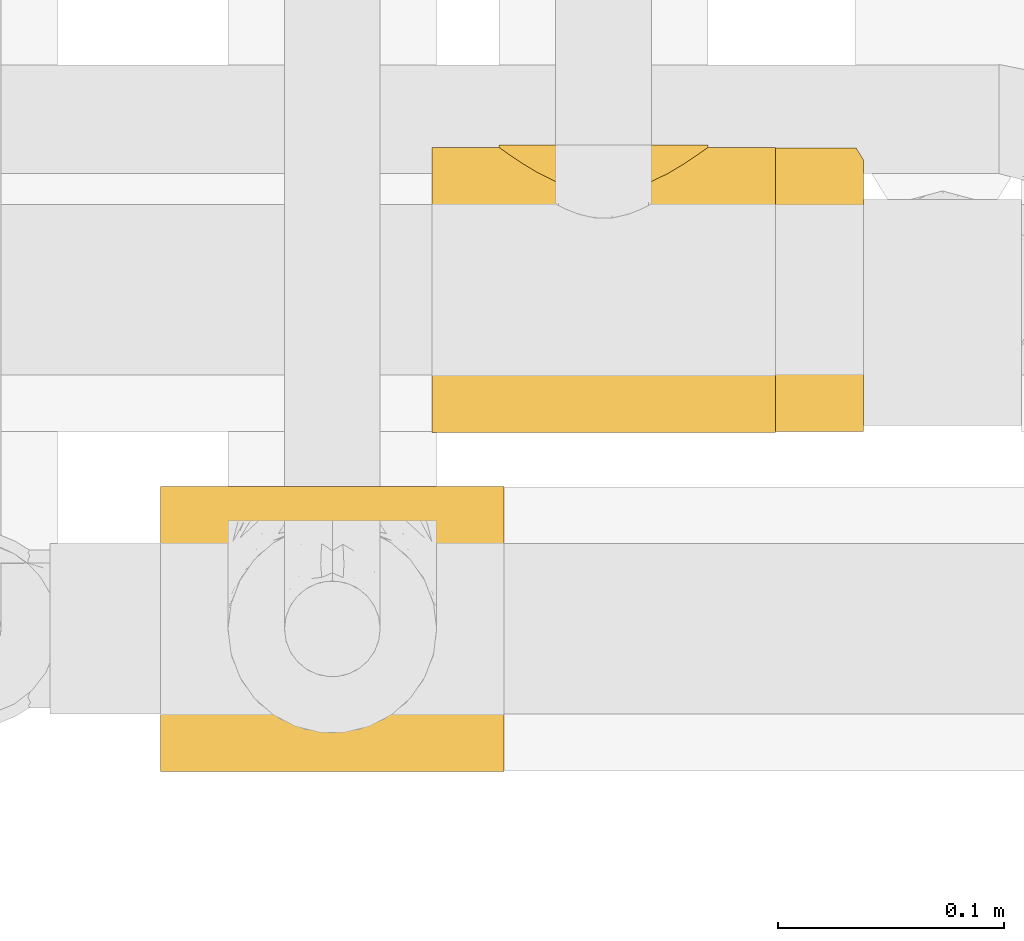
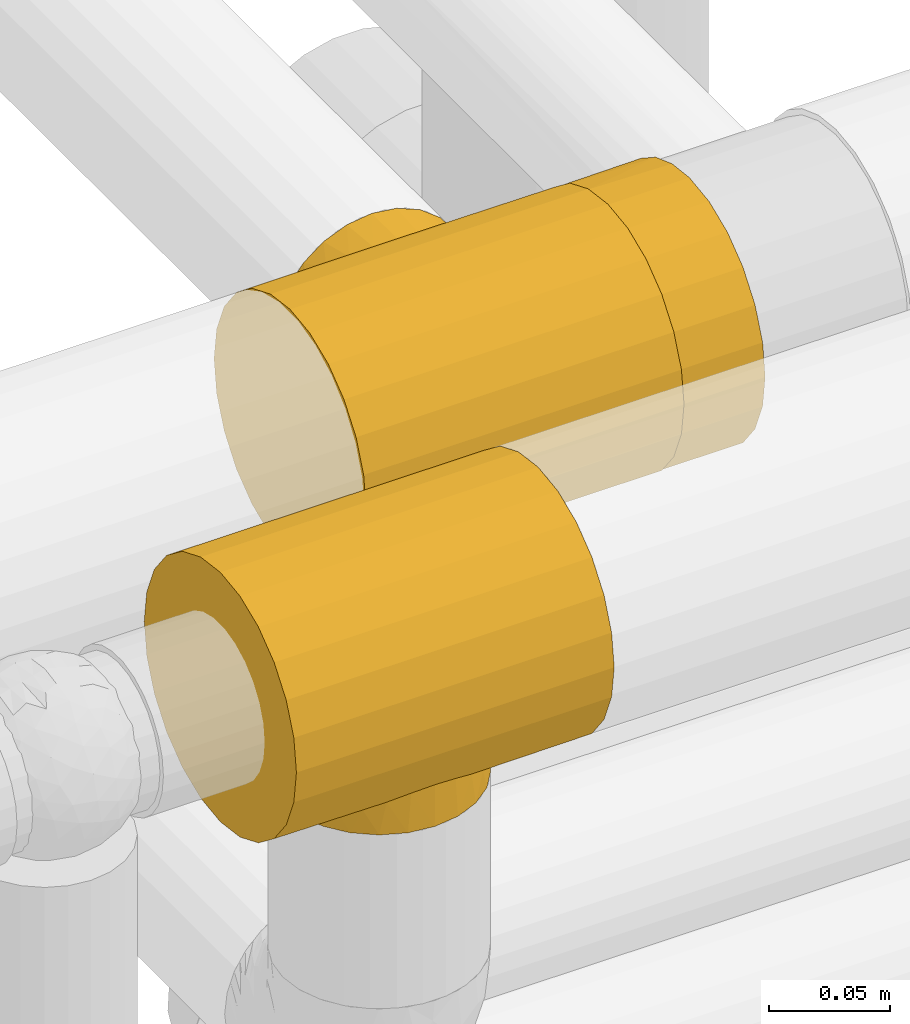
# One storey, part 419 of 827: 3 coverings.
"""IFC2X3 building model written with IfcOpenShell, lengths in millimetres."""

import ifcopenshell
import ifcopenshell.guid

model = None  # the IFC model being written
_history = None  # IfcOwnerHistory: only IFC2X3 demands one
_inside = {}  # id of a spatial element -> (the spatial element, [elements in it])
_under = {}  # id of a project, library or spatial element -> (it, [spatial elements below it])
_declared = {}  # id of a project -> (the project, [libraries it declares])
_typed = {}  # id of a type object -> (the type object, [elements of that type])
_made_of = {}  # id of a material, layer set ... -> (it, [elements and type objects made of it])


def new_model(schema):
    """Start an empty IFC model of exactly this schema.

    Asked for "IFC4X3", IfcOpenShell would pick the latest addendum, in which some entities
    have other attributes; the version numbers below select the first issue.
    IFC2X3 requires an IfcOwnerHistory on every rooted entity: one is made here for all.
    """
    global model, _history
    if schema == "IFC4X3":
        model = ifcopenshell.file(schema_version=(4, 3, 0, 0))
    else:
        model = ifcopenshell.file(schema=schema)
    _inside.clear()
    _under.clear()
    _declared.clear()
    _typed.clear()
    _made_of.clear()
    _history = None
    if model.schema == "IFC2X3":
        org = make("IfcOrganization", Name="unknown")
        user = make(
            "IfcPersonAndOrganization",
            ThePerson=make("IfcPerson", FamilyName="unknown"),
            TheOrganization=org,
        )
        app = make(
            "IfcApplication",
            ApplicationDeveloper=org,
            Version="unknown",
            ApplicationFullName="unknown",
            ApplicationIdentifier="unknown",
        )
        _history = make(
            "IfcOwnerHistory",
            OwningUser=user,
            OwningApplication=app,
            ChangeAction="ADDED",
            CreationDate=0,
        )
    return model


def make(cls, **values):
    """One entity of the class cls with the attributes given. An attribute that is None is left unset."""
    return model.create_entity(
        cls, **{name: value for name, value in values.items() if value is not None}
    )


def entity(cls, *values):
    """Any entity or typed value of the class cls, its attributes in the order of the schema. None: left unset."""
    e = model.create_entity(cls)
    for i, value in enumerate(values):
        if value is not None:
            e[i] = value
    return e


def rooted(cls, **values):
    """An entity with a GlobalId (a new one), such as an element, a storey or a relation."""
    return make(cls, GlobalId=ifcopenshell.guid.new(), OwnerHistory=_history, **values)


def si_unit(unit_type, name, prefix=None):
    """IfcSIUnit, for example si_unit("LENGTHUNIT", "METRE", prefix="MILLI")."""
    return make("IfcSIUnit", UnitType=unit_type, Prefix=prefix, Name=name)


def converted_unit(unit_type, name, factor, base, dimensions=None, offset=None):
    """IfcConversionBasedUnit, such as the inch: factor (a typed value) times the base unit."""
    return make(
        "IfcConversionBasedUnit"
        if offset is None
        else "IfcConversionBasedUnitWithOffset",
        ConversionOffset=offset,
        Dimensions=None
        if dimensions is None
        else entity("IfcDimensionalExponents", *dimensions),
        UnitType=unit_type,
        Name=name,
        ConversionFactor=make(
            "IfcMeasureWithUnit", ValueComponent=factor, UnitComponent=base
        ),
    )


def derived_unit(unit_type, elements):
    """IfcDerivedUnit: a product of units, each with its exponent."""
    return make(
        "IfcDerivedUnit",
        Elements=[
            make("IfcDerivedUnitElement", Unit=unit, Exponent=power)
            for unit, power in elements
        ],
        UnitType=unit_type,
    )


def assignment(units):
    """IfcUnitAssignment: the units of a project."""
    return None if units is None else make("IfcUnitAssignment", Units=units)


def point(xyz):
    """IfcCartesianPoint."""
    return None if xyz is None else make("IfcCartesianPoint", Coordinates=xyz)


def direction(xyz):
    """IfcDirection."""
    return None if xyz is None else make("IfcDirection", DirectionRatios=xyz)


def frame(location, z_axis=None, x_axis=None):
    """IfcAxis2Placement3D, a coordinate frame: its origin and axes. An axis left out is left unset."""
    return make(
        "IfcAxis2Placement3D",
        Location=point(location),
        Axis=direction(z_axis),
        RefDirection=direction(x_axis),
    )


def origin():
    """The frame at (0, 0, 0) with its axes left unset."""
    return frame((0.0, 0.0, 0.0))


def place(relative_to, where):
    """IfcLocalPlacement: puts the frame where relative to a parent placement (None: the world)."""
    return make(
        "IfcLocalPlacement", PlacementRelTo=relative_to, RelativePlacement=where
    )


def context(
    kind, dimensions, precision=None, world=None, true_north=None, identifier=None
):
    """IfcGeometricRepresentationContext, for example the 3D "Model" context."""
    return make(
        "IfcGeometricRepresentationContext",
        ContextIdentifier=identifier,
        ContextType=kind,
        CoordinateSpaceDimension=dimensions,
        Precision=precision,
        WorldCoordinateSystem=world,
        TrueNorth=true_north,
    )


def subcontext(parent, identifier, kind, view, scale=None):
    """IfcGeometricRepresentationSubContext, for example "Body" below "Model"."""
    return make(
        "IfcGeometricRepresentationSubContext",
        ContextIdentifier=identifier,
        ContextType=kind,
        ParentContext=parent,
        TargetScale=scale,
        TargetView=view,
    )


def project(units=None, contexts=None):
    """IfcProject with its units and contexts."""
    return rooted(
        "IfcProject",
        Name="project",
        RepresentationContexts=contexts,
        UnitsInContext=assignment(units),
    )


def spatial(cls, under=None, at=None, **own):
    """A site, building, storey or space (cls), placed at a placement, below another one or the project."""
    s = rooted(cls, ObjectPlacement=at, **own)
    if under is not None:
        _under.setdefault(under.id(), (under, []))[1].append(s)
    return s


def faces_of(points, faces, orient=None, outer=None):
    """IfcFace entities. A face is a list of loops; a loop is a list of indices into points, from 0.

    orient and outer hold one flag for each loop. By default every Orientation is true, the
    first loop of a face is its IfcFaceOuterBound and the others are IfcFaceBound.
    """
    made = []
    for i, loops in enumerate(faces):
        bounds = []
        for j, loop in enumerate(loops):
            is_outer = j == 0 if outer is None else outer[i][j]
            bounds.append(
                make(
                    "IfcFaceOuterBound" if is_outer else "IfcFaceBound",
                    Bound=make("IfcPolyLoop", Polygon=[points[k] for k in loop]),
                    Orientation=True if orient is None else orient[i][j],
                )
            )
        made.append(make("IfcFace", Bounds=bounds))
    return made


def faceted_brep(points, faces, orient=None, outer=None, voids=None):
    """IfcFacetedBrep: a solid bounded by flat faces; with voids (closed shells), ...WithVoids."""
    shared = [point(p) for p in points]
    hull = make("IfcClosedShell", CfsFaces=faces_of(shared, faces, orient, outer))
    if voids is None:
        return make("IfcFacetedBrep", Outer=hull)
    return make(
        "IfcFacetedBrepWithVoids",
        Outer=hull,
        Voids=[
            make(cls, CfsFaces=faces_of(shared, fs, o, b)) for cls, fs, o, b in voids
        ],
    )


def shape(context_of_items, identifier, shape_type, items):
    """IfcShapeRepresentation: the items that make up one representation, for example the "Body"."""
    return make(
        "IfcShapeRepresentation",
        ContextOfItems=context_of_items,
        RepresentationIdentifier=identifier,
        RepresentationType=shape_type,
        Items=items,
    )


def made_of(thing, what):
    """Note that an element or type object is made of a material, layer set ...; save() writes the relation."""
    if what is not None:
        _made_of.setdefault(what.id(), (what, []))[1].append(thing)
    return thing


def element(
    cls,
    number,
    at=None,
    inside=None,
    cuts=None,
    type_object=None,
    material=None,
    context=None,
    identifier="Body",
    shape_type=None,
    held_by="IfcProductDefinitionShape",
    body=None,
    shapes=None,
    **own,
):
    """One element of the class cls, such as IfcWall. Its Tag is "e" and its number.

    at: its placement. inside: the storey or other place that contains it. cuts: it is an
    opening in that element (IfcRelVoidsElement). A single representation is given by context,
    identifier, shape_type and body (its items); several are given by shapes. held_by: the class
    of the entity that holds the representations. save() writes the other relations.
    """
    e = rooted(cls, Tag="e%d" % number, ObjectPlacement=at, **own)
    if body is not None:
        shapes = [shape(context, identifier, shape_type, body)]
    if shapes is not None:
        e.Representation = make(held_by, Representations=shapes)
    if inside is not None:
        _inside.setdefault(inside.id(), (inside, []))[1].append(e)
    if cuts is not None:
        rooted(
            "IfcRelVoidsElement", RelatingBuildingElement=cuts, RelatedOpeningElement=e
        )
    if type_object is not None:
        _typed.setdefault(type_object.id(), (type_object, []))[1].append(e)
    return made_of(e, material)


def aggregate(whole, parts):
    """IfcRelAggregates: a whole, such as a stair, and the parts it consists of."""
    return rooted("IfcRelAggregates", RelatingObject=whole, RelatedObjects=parts)


def save(model, path):
    """Write the relations noted so far, then the file.

    IfcRelAggregates (storeys below a building ...), IfcRelContainedInSpatialStructure (elements
    in a storey), IfcRelDefinesByType, IfcRelAssociatesMaterial and IfcRelDeclares: one each for
    every whole, place, type object, material and project.
    """
    for whole, parts in _under.values():
        aggregate(whole, parts)
    for where, things in _inside.values():
        rooted(
            "IfcRelContainedInSpatialStructure",
            RelatedElements=things,
            RelatingStructure=where,
        )
    for kind, things in _typed.values():
        rooted("IfcRelDefinesByType", RelatedObjects=things, RelatingType=kind)
    for what, things in _made_of.values():
        rooted("IfcRelAssociatesMaterial", RelatedObjects=things, RelatingMaterial=what)
    for by, libraries in _declared.values():
        rooted("IfcRelDeclares", RelatingContext=by, RelatedDefinitions=libraries)
    model.write(path)


model = new_model("IFC2X3")

# Units and contexts
model_context = context("Model", 3, precision=0.01, world=origin(), true_north=direction((6.12303176911189e-17, 1.0)))
body_context = subcontext(model_context, "Body", "Model", "MODEL_VIEW")
ifc_project = project(units=[si_unit("LENGTHUNIT", "METRE", prefix="MILLI"), si_unit("AREAUNIT", "SQUARE_METRE"), si_unit("VOLUMEUNIT", "CUBIC_METRE"), converted_unit("PLANEANGLEUNIT", "DEGREE", entity("IfcRatioMeasure", 0.0174532925199433), si_unit("PLANEANGLEUNIT", "RADIAN"), dimensions=[0, 0, 0, 0, 0, 0, 0]), si_unit("MASSUNIT", "GRAM", prefix="KILO"), derived_unit("MASSDENSITYUNIT", [(si_unit("MASSUNIT", "GRAM", prefix="KILO"), 1), (si_unit("LENGTHUNIT", "METRE"), -3)]), derived_unit("MOMENTOFINERTIAUNIT", [(si_unit("LENGTHUNIT", "METRE"), 4)]), si_unit("TIMEUNIT", "SECOND"), si_unit("FREQUENCYUNIT", "HERTZ"), si_unit("THERMODYNAMICTEMPERATUREUNIT", "DEGREE_CELSIUS"), derived_unit("THERMALTRANSMITTANCEUNIT", [(si_unit("MASSUNIT", "GRAM", prefix="KILO"), 1), (si_unit("THERMODYNAMICTEMPERATUREUNIT", "KELVIN"), -1), (si_unit("TIMEUNIT", "SECOND"), -3)]), derived_unit("VOLUMETRICFLOWRATEUNIT", [(si_unit("LENGTHUNIT", "METRE"), 3), (si_unit("TIMEUNIT", "SECOND"), -1)]), derived_unit("MASSFLOWRATEUNIT", [(si_unit("MASSUNIT", "GRAM", prefix="KILO"), 1), (si_unit("TIMEUNIT", "SECOND"), -1)]), derived_unit("ROTATIONALFREQUENCYUNIT", [(si_unit("TIMEUNIT", "SECOND"), -1)]), si_unit("ELECTRICCURRENTUNIT", "AMPERE"), si_unit("ELECTRICVOLTAGEUNIT", "VOLT"), si_unit("POWERUNIT", "WATT"), si_unit("FORCEUNIT", "NEWTON", prefix="KILO"), si_unit("ILLUMINANCEUNIT", "LUX"), si_unit("LUMINOUSFLUXUNIT", "LUMEN"), si_unit("LUMINOUSINTENSITYUNIT", "CANDELA"), derived_unit("USERDEFINED", [(si_unit("MASSUNIT", "GRAM", prefix="KILO"), -1), (si_unit("LENGTHUNIT", "METRE"), -2), (si_unit("TIMEUNIT", "SECOND"), 3), (si_unit("LUMINOUSFLUXUNIT", "LUMEN"), 1)]), derived_unit("LINEARVELOCITYUNIT", [(si_unit("LENGTHUNIT", "METRE"), 1), (si_unit("TIMEUNIT", "SECOND"), -1)]), si_unit("PRESSUREUNIT", "PASCAL"), derived_unit("USERDEFINED", [(si_unit("LENGTHUNIT", "METRE"), -2), (si_unit("MASSUNIT", "GRAM", prefix="KILO"), 1), (si_unit("TIMEUNIT", "SECOND"), -2)]), derived_unit("LINEARFORCEUNIT", [(si_unit("MASSUNIT", "GRAM", prefix="KILO"), 1), (si_unit("LENGTHUNIT", "METRE"), 1), (si_unit("TIMEUNIT", "SECOND"), -2), (si_unit("LENGTHUNIT", "METRE"), -1)]), derived_unit("PLANARFORCEUNIT", [(si_unit("MASSUNIT", "GRAM", prefix="KILO"), 1), (si_unit("LENGTHUNIT", "METRE"), 1), (si_unit("TIMEUNIT", "SECOND"), -2), (si_unit("LENGTHUNIT", "METRE"), -2)])], contexts=[model_context])

# Site, building, storey
site_placement = place(None, origin())
site = spatial("IfcSite", under=ifc_project, at=site_placement, CompositionType="ELEMENT")
building_placement = place(site_placement, origin())
building = spatial("IfcBuilding", under=site, at=building_placement, CompositionType="ELEMENT")
storey_placement = place(building_placement, frame((0.0, 0.0, 28200.0)))
storey = spatial("IfcBuildingStorey", under=building, at=storey_placement, Name="08", CompositionType="ELEMENT", Elevation=28200.0)

# Coverings
covering_1_placement = place(storey_placement, frame((54113.79, 16007.73, 2635.35)))
element("IfcCovering", 1, at=covering_1_placement, inside=storey, Name=":ADSK_", ObjectType=":ADSK_", PredefinedType="INSULATION", context=body_context, shape_type="Brep", body=[
    faceted_brep([(0.0, 10.04, 33.12), (0.0, 3.74, 48.33), (0.0, 1.6, 64.65), (0.0, 3.74, 80.96), (0.0, 10.04, 96.17), (0.0, 20.06, 109.23), (0.0, 33.12, 119.25), (0.0, 48.33, 125.55), (0.0, 64.65, 127.7), (0.0, 80.96, 125.55), (0.0, 96.17, 119.25), (0.0, 109.23, 109.23), (0.0, 114.24, 102.7), (0.0, 119.25, 96.17), (0.0, 122.4, 88.57), (0.0, 125.55, 80.96), (0.0, 126.62, 72.8), (0.0, 127.7, 64.65), (0.0, 126.62, 56.49), (0.0, 125.55, 48.33), (0.0, 122.4, 40.72), (0.0, 119.25, 33.12), (0.0, 114.24, 26.59), (0.0, 109.23, 20.06), (0.0, 96.17, 10.04), (0.0, 80.96, 3.74), (0.0, 64.65, 1.6), (0.0, 48.33, 3.74), (0.0, 33.12, 10.04), (0.0, 20.06, 20.06), (152.0, 64.65, 127.7), (152.0, 48.33, 125.55), (152.0, 33.12, 119.25), (152.0, 20.06, 109.23), (152.0, 10.04, 96.17), (152.0, 3.74, 80.96), (152.0, 1.6, 64.65), (152.0, 3.74, 48.33), (152.0, 10.04, 33.12), (152.0, 20.06, 20.06), (152.0, 33.12, 10.04), (152.0, 48.33, 3.74), (152.0, 64.65, 1.6), (152.0, 80.96, 3.74), (152.0, 96.17, 10.04), (152.0, 109.23, 20.06), (152.0, 114.24, 26.59), (152.0, 119.25, 33.12), (152.0, 122.4, 40.72), (152.0, 125.55, 48.33), (152.0, 126.62, 56.49), (152.0, 127.7, 64.65), (152.0, 126.62, 72.8), (152.0, 125.55, 80.96), (152.0, 122.4, 88.57), (152.0, 119.25, 96.17), (152.0, 114.24, 102.7), (152.0, 109.23, 109.23), (152.0, 96.17, 119.25), (152.0, 80.96, 125.55), (96.34, 112.13, 106.13), (104.78, 116.31, 100.79), (34.64, 124.24, 85.23), (86.64, 108.85, 109.6), (76.0, 107.55, 110.85), (65.36, 108.85, 109.6), (30.43, 127.24, 70.0), (30.27, 127.35, 68.66), (30.11, 127.47, 67.32), (29.96, 127.58, 65.98), (29.8, 127.7, 64.65), (122.2, 127.7, 64.65), (122.04, 127.58, 65.98), (121.89, 127.47, 67.32), (121.73, 127.35, 68.66), (121.57, 127.24, 70.0), (55.66, 112.13, 106.13), (47.22, 116.31, 100.79), (117.36, 124.24, 85.23), (114.61, 122.4, 89.51), (111.85, 120.56, 93.79), (32.85, 125.51, 80.29), (31.95, 126.15, 77.82), (31.06, 126.78, 75.35), (120.94, 126.78, 75.35), (121.26, 127.01, 72.67), (120.05, 126.15, 77.82), (119.15, 125.51, 80.29), (40.15, 120.56, 93.79), (37.39, 122.4, 89.51), (30.74, 127.01, 72.67), (121.57, 127.24, 59.29), (120.94, 126.78, 53.94), (111.85, 120.56, 35.5), (114.61, 122.4, 39.78), (117.36, 124.24, 44.06), (119.15, 125.51, 49.0), (120.05, 126.15, 51.47), (121.26, 127.01, 56.62), (30.43, 127.24, 59.29), (30.74, 127.01, 56.62), (31.06, 126.78, 53.94), (29.96, 127.58, 63.31), (30.11, 127.47, 61.97), (30.27, 127.35, 60.63), (121.73, 127.35, 60.63), (121.89, 127.47, 61.97), (122.04, 127.58, 63.31), (40.15, 120.56, 35.5), (34.64, 124.24, 44.06), (47.22, 116.31, 28.5), (31.95, 126.15, 51.47), (32.85, 125.51, 49.0), (104.78, 116.31, 28.5), (96.34, 112.13, 23.17), (86.64, 108.85, 19.69), (76.0, 107.55, 18.45), (55.66, 112.13, 23.17), (65.36, 108.85, 19.69), (37.39, 122.4, 39.78), (76.0, 128.65, 110.85), (87.96, 128.65, 109.27), (99.1, 128.65, 104.66), (108.67, 128.65, 97.31), (116.01, 128.65, 87.75), (118.32, 128.65, 82.17), (119.47, 128.65, 79.39), (120.63, 128.65, 76.6), (120.82, 128.65, 75.11), (121.02, 128.65, 73.61), (121.22, 128.65, 72.12), (121.41, 128.65, 70.62), (121.61, 128.65, 69.13), (121.81, 128.65, 67.63), (122.0, 128.65, 66.14), (122.2, 128.65, 64.65), (122.0, 128.65, 63.15), (121.81, 128.65, 61.66), (121.61, 128.65, 60.16), (121.41, 128.65, 58.67), (121.22, 128.65, 57.17), (121.02, 128.65, 55.68), (120.82, 128.65, 54.18), (120.63, 128.65, 52.69), (119.47, 128.65, 49.9), (118.32, 128.65, 47.12), (116.01, 128.65, 41.55), (108.67, 128.65, 31.98), (99.1, 128.65, 24.63), (87.96, 128.65, 20.02), (76.0, 128.65, 18.45), (64.04, 128.65, 20.02), (52.9, 128.65, 24.63), (43.33, 128.65, 31.98), (35.99, 128.65, 41.55), (33.68, 128.65, 47.12), (32.53, 128.65, 49.9), (31.37, 128.65, 52.69), (31.18, 128.65, 54.18), (30.98, 128.65, 55.68), (30.78, 128.65, 57.17), (30.59, 128.65, 58.67), (30.39, 128.65, 60.16), (30.19, 128.65, 61.66), (30.0, 128.65, 63.15), (29.8, 128.65, 64.65), (30.0, 128.65, 66.14), (30.19, 128.65, 67.63), (30.39, 128.65, 69.13), (30.59, 128.65, 70.62), (30.78, 128.65, 72.12), (30.98, 128.65, 73.61), (31.18, 128.65, 75.11), (31.37, 128.65, 76.6), (32.53, 128.65, 79.39), (33.68, 128.65, 82.17), (35.99, 128.65, 87.75), (43.33, 128.65, 97.31), (52.9, 128.65, 104.66), (64.04, 128.65, 109.27)], [[[0, 1, 2, 3, 4, 5, 6, 7, 8, 9, 10, 11, 12, 13, 14, 15, 16, 17, 18, 19, 20, 21, 22, 23, 24, 25, 26, 27, 28, 29]], [[30, 31, 32, 33, 34, 35, 36, 37, 38, 39, 40, 41, 42, 43, 44, 45, 46, 47, 48, 49, 50, 51, 52, 53, 54, 55, 56, 57, 58, 59]], [[34, 33, 5, 4]], [[2, 36, 35, 3]], [[4, 3, 35, 34]], [[6, 32, 31, 7]], [[7, 31, 30, 8]], [[5, 33, 32, 6]], [[59, 9, 8, 30]], [[58, 10, 9, 59]], [[56, 60, 57]], [[61, 56, 55]], [[62, 15, 14]], [[60, 63, 57]], [[60, 56, 61]], [[58, 57, 64]], [[57, 63, 64]], [[64, 65, 11]], [[17, 66, 67, 68, 69, 70]], [[51, 71, 72, 73, 74, 75]], [[12, 76, 77]], [[76, 11, 65]], [[77, 13, 12]], [[64, 11, 10]], [[64, 10, 58]], [[54, 78, 79, 80]], [[54, 80, 55]], [[78, 54, 53]], [[15, 62, 81, 82, 83]], [[84, 53, 52]], [[51, 75, 52]], [[52, 75, 85, 84]], [[53, 84, 86, 87, 78]], [[77, 88, 13]], [[88, 14, 13]], [[14, 88, 89, 62]], [[16, 83, 90, 66]], [[12, 11, 76]], [[17, 16, 66]], [[16, 15, 83]], [[80, 61, 55]], [[50, 91, 51]], [[92, 50, 49]], [[47, 93, 48]], [[48, 93, 94, 95]], [[95, 49, 48]], [[49, 95, 96, 97, 92]], [[50, 92, 98, 91]], [[18, 99, 100, 101]], [[17, 70, 102, 103, 104, 99]], [[51, 91, 105, 106, 107, 71]], [[108, 21, 20]], [[17, 99, 18]], [[20, 19, 109]], [[21, 108, 110]], [[109, 19, 101, 111, 112]], [[113, 47, 46]], [[113, 93, 47]], [[46, 114, 113]], [[114, 46, 45]], [[114, 45, 115]], [[24, 44, 43, 25]], [[44, 116, 45]], [[45, 116, 115]], [[43, 42, 26, 25]], [[101, 19, 18]], [[117, 118, 23]], [[20, 109, 119, 108]], [[110, 22, 21]], [[22, 117, 23]], [[118, 116, 23]], [[116, 24, 23]], [[116, 44, 24]], [[117, 22, 110]], [[27, 41, 40, 28]], [[28, 40, 39, 29]], [[42, 41, 27, 26]], [[0, 38, 37, 1]], [[1, 37, 36, 2]], [[29, 39, 38, 0]], [[120, 121, 122, 123, 124, 125, 126, 127, 128, 129, 130, 131, 132, 133, 134, 135, 136, 137, 138, 139, 140, 141, 142, 143, 144, 145, 146, 147, 148, 149, 150, 151, 152, 153, 154, 155, 156, 157, 158, 159, 160, 161, 162, 163, 164, 165, 166, 167, 168, 169, 170, 171, 172, 173, 174, 175, 176, 177, 178, 179]], [[84, 129, 128, 127]], [[132, 75, 74]], [[74, 133, 132]], [[78, 125, 124]], [[73, 134, 133]], [[132, 131, 75]], [[127, 86, 84]], [[79, 78, 124]], [[86, 126, 87]], [[123, 79, 124]], [[123, 80, 79]], [[87, 126, 125]], [[61, 123, 122]], [[85, 131, 130, 129]], [[122, 121, 60]], [[129, 84, 85]], [[72, 135, 134]], [[120, 63, 121]], [[125, 78, 87]], [[61, 122, 60]], [[86, 127, 126]], [[63, 60, 121]], [[64, 63, 120]], [[131, 85, 75]], [[123, 61, 80]], [[133, 74, 73]], [[135, 72, 71]], [[134, 73, 72]], [[65, 120, 179]], [[69, 165, 70]], [[90, 171, 170, 169]], [[76, 179, 178]], [[173, 83, 82]], [[64, 120, 65]], [[176, 62, 89]], [[65, 179, 76]], [[178, 77, 76]], [[83, 173, 172, 171]], [[178, 177, 77]], [[167, 67, 168]], [[177, 176, 89]], [[167, 68, 67]], [[175, 174, 81]], [[81, 174, 82]], [[67, 66, 168]], [[169, 66, 90]], [[88, 177, 89]], [[62, 176, 175]], [[171, 90, 83]], [[175, 81, 62]], [[82, 174, 173]], [[166, 69, 68]], [[177, 88, 77]], [[66, 169, 168]], [[68, 167, 166]], [[165, 69, 166]], [[101, 159, 158, 157]], [[162, 99, 104]], [[104, 163, 162]], [[109, 155, 154]], [[103, 164, 163]], [[162, 161, 99]], [[157, 111, 101]], [[119, 109, 154]], [[111, 156, 112]], [[153, 119, 154]], [[153, 108, 119]], [[112, 156, 155]], [[110, 153, 152]], [[100, 161, 160, 159]], [[152, 151, 117]], [[159, 101, 100]], [[102, 165, 164]], [[150, 118, 151]], [[155, 109, 112]], [[110, 152, 117]], [[111, 157, 156]], [[118, 117, 151]], [[116, 118, 150]], [[161, 100, 99]], [[153, 110, 108]], [[163, 104, 103]], [[165, 102, 70]], [[164, 103, 102]], [[115, 150, 149]], [[107, 135, 71]], [[98, 141, 140, 139]], [[114, 149, 148]], [[143, 92, 97]], [[116, 150, 115]], [[146, 95, 94]], [[115, 149, 114]], [[148, 113, 114]], [[92, 143, 142, 141]], [[148, 147, 113]], [[137, 105, 138]], [[147, 146, 94]], [[137, 106, 105]], [[145, 144, 96]], [[96, 144, 97]], [[105, 91, 138]], [[139, 91, 98]], [[93, 147, 94]], [[95, 146, 145]], [[141, 98, 92]], [[145, 96, 95]], [[97, 144, 143]], [[136, 107, 106]], [[147, 93, 113]], [[91, 139, 138]], [[106, 137, 136]], [[135, 107, 136]]]),
])
covering_2_placement = place(storey_placement, frame((54265.79, 16008.03, 2635.69)))
element("IfcCovering", 2, at=covering_2_placement, inside=storey, Name=":ADSK_", ObjectType=":ADSK_", PredefinedType="INSULATION", context=body_context, shape_type="Brep", body=[
    faceted_brep([(0.0, 3.73, 48.1), (0.0, 1.6, 64.35), (0.0, 3.73, 80.59), (0.0, 10.0, 95.72), (0.0, 19.97, 108.72), (0.0, 32.97, 118.69), (0.0, 48.1, 124.96), (0.0, 64.35, 127.1), (0.0, 80.59, 124.96), (0.0, 95.72, 118.69), (0.0, 108.72, 108.72), (0.0, 118.69, 95.72), (0.0, 124.96, 80.59), (0.0, 127.1, 64.35), (0.0, 124.96, 48.1), (0.0, 118.69, 32.97), (0.0, 108.72, 19.97), (0.0, 95.72, 10.0), (0.0, 80.59, 3.73), (0.0, 64.35, 1.6), (0.0, 48.1, 3.73), (0.0, 32.97, 10.0), (0.0, 19.97, 19.97), (0.0, 10.0, 32.97), (39.0, 114.54, 26.69), (39.0, 121.85, 39.22), (39.0, 121.85, 89.47), (39.0, 114.54, 102.0), (39.0, 104.55, 112.52), (39.0, 92.41, 120.47), (39.0, 78.77, 125.41), (39.0, 64.35, 127.1), (39.0, 48.1, 124.96), (39.0, 32.97, 118.69), (39.0, 19.97, 108.72), (39.0, 10.0, 95.72), (39.0, 3.73, 80.59), (39.0, 1.6, 64.35), (39.0, 3.73, 48.1), (39.0, 10.0, 32.97), (39.0, 19.97, 19.97), (39.0, 32.97, 10.0), (39.0, 48.1, 3.73), (39.0, 64.35, 1.6), (39.0, 78.77, 3.28), (39.0, 92.41, 8.22), (39.0, 104.55, 16.17), (36.61, 125.77, 51.51), (35.8, 127.1, 64.35), (36.61, 125.77, 77.18)], [[[0, 1, 2, 3, 4, 5, 6, 7, 8, 9, 10, 11, 12, 13, 14, 15, 16, 17, 18, 19, 20, 21, 22, 23]], [[24, 25, 26, 27, 28, 29, 30, 31, 32, 33, 34, 35, 36, 37, 38, 39, 40, 41, 42, 43, 44, 45, 46]], [[14, 47, 25]], [[15, 25, 24]], [[48, 47, 13]], [[13, 47, 14]], [[25, 15, 14]], [[24, 16, 15]], [[46, 45, 17]], [[45, 44, 18]], [[19, 44, 43]], [[17, 16, 46]], [[18, 17, 45]], [[44, 19, 18]], [[46, 16, 24]], [[19, 43, 42, 20]], [[20, 42, 41, 21]], [[21, 41, 40, 22]], [[38, 37, 1, 0]], [[39, 38, 0, 23]], [[22, 40, 39, 23]], [[1, 37, 36, 2]], [[2, 36, 35, 3]], [[3, 35, 34, 4]], [[5, 33, 32, 6]], [[6, 32, 31, 7]], [[4, 34, 33, 5]], [[7, 31, 30]], [[8, 30, 29]], [[7, 30, 8]], [[9, 28, 10]], [[9, 8, 29]], [[28, 9, 29]], [[11, 27, 26]], [[49, 48, 13]], [[12, 26, 49]], [[10, 27, 11]], [[12, 11, 26]], [[13, 12, 49]], [[27, 10, 28]], [[48, 49, 26, 25, 47]]]),
])
covering_3_placement = place(storey_placement, frame((53993.79, 15857.73, 2635.35)))
element("IfcCovering", 3, at=covering_3_placement, inside=storey, Name=":ADSK_", ObjectType=":ADSK_", PredefinedType="INSULATION", context=body_context, shape_type="Brep", body=[
    faceted_brep([(152.0, 96.17, 119.25), (152.0, 80.96, 125.55), (152.0, 64.65, 127.7), (152.0, 48.33, 125.55), (152.0, 33.12, 119.25), (152.0, 20.06, 109.23), (152.0, 10.04, 96.17), (152.0, 3.74, 80.96), (152.0, 1.6, 64.65), (152.0, 3.74, 48.33), (152.0, 10.04, 33.12), (152.0, 20.06, 20.06), (152.0, 26.59, 15.05), (152.0, 33.12, 10.04), (152.0, 40.72, 6.89), (152.0, 48.33, 3.74), (152.0, 56.49, 2.67), (152.0, 64.65, 1.6), (152.0, 72.8, 2.67), (152.0, 80.96, 3.74), (152.0, 88.57, 6.89), (152.0, 96.17, 10.04), (152.0, 102.7, 15.05), (152.0, 109.23, 20.06), (152.0, 119.25, 33.12), (152.0, 125.55, 48.33), (152.0, 127.7, 64.65), (152.0, 125.55, 80.96), (152.0, 119.25, 96.17), (152.0, 109.23, 109.23), (0.0, 1.6, 64.65), (0.0, 3.74, 80.96), (0.0, 10.04, 96.17), (0.0, 20.06, 109.23), (0.0, 33.12, 119.25), (0.0, 48.33, 125.55), (0.0, 64.65, 127.7), (0.0, 80.96, 125.55), (0.0, 96.17, 119.25), (0.0, 109.23, 109.23), (0.0, 119.25, 96.17), (0.0, 125.55, 80.96), (0.0, 127.7, 64.65), (0.0, 125.55, 48.33), (0.0, 119.25, 33.12), (0.0, 109.23, 20.06), (0.0, 102.7, 15.05), (0.0, 96.17, 10.04), (0.0, 88.57, 6.89), (0.0, 80.96, 3.74), (0.0, 72.8, 2.67), (0.0, 64.65, 1.6), (0.0, 56.49, 2.67), (0.0, 48.33, 3.74), (0.0, 40.72, 6.89), (0.0, 33.12, 10.04), (0.0, 26.59, 15.05), (0.0, 20.06, 20.06), (0.0, 10.04, 33.12), (0.0, 3.74, 48.33), (55.66, 23.17, 17.16), (47.22, 28.5, 12.98), (117.36, 44.06, 5.05), (65.36, 19.69, 20.44), (76.0, 18.45, 21.74), (86.64, 19.69, 20.44), (121.57, 59.29, 2.05), (121.73, 60.63, 1.94), (121.89, 61.97, 1.82), (122.04, 63.31, 1.71), (122.2, 64.65, 1.6), (29.8, 64.65, 1.6), (29.96, 63.31, 1.71), (30.11, 61.97, 1.82), (30.27, 60.63, 1.94), (30.43, 59.29, 2.05), (96.34, 23.17, 17.16), (104.78, 28.5, 12.98), (34.64, 44.06, 5.05), (37.39, 39.78, 6.89), (40.15, 35.5, 8.73), (119.15, 49.0, 3.78), (120.05, 51.47, 3.15), (120.94, 53.94, 2.51), (31.06, 53.94, 2.51), (30.74, 56.62, 2.28), (31.95, 51.47, 3.15), (32.85, 49.0, 3.78), (111.85, 35.5, 8.73), (114.61, 39.78, 6.89), (121.26, 56.62, 2.28), (30.43, 70.0, 2.05), (31.06, 75.35, 2.51), (40.15, 93.79, 8.73), (37.39, 89.51, 6.89), (34.64, 85.23, 5.05), (32.85, 80.29, 3.78), (31.95, 77.82, 3.15), (30.74, 72.67, 2.28), (121.57, 70.0, 2.05), (121.26, 72.67, 2.28), (120.94, 75.35, 2.51), (122.04, 65.98, 1.71), (121.89, 67.32, 1.82), (121.73, 68.66, 1.94), (30.27, 68.66, 1.94), (30.11, 67.32, 1.82), (29.96, 65.98, 1.71), (111.85, 93.79, 8.73), (117.36, 85.23, 5.05), (104.78, 100.79, 12.98), (120.05, 77.82, 3.15), (119.15, 80.29, 3.78), (47.22, 100.79, 12.98), (55.66, 106.13, 17.16), (65.36, 109.6, 20.44), (76.0, 110.85, 21.74), (96.34, 106.13, 17.16), (86.64, 109.6, 20.44), (114.61, 89.51, 6.89), (76.0, 18.45, 0.65), (64.04, 20.02, 0.65), (52.9, 24.63, 0.65), (43.33, 31.98, 0.65), (35.99, 41.55, 0.65), (33.68, 47.12, 0.65), (32.53, 49.9, 0.65), (31.37, 52.69, 0.65), (31.18, 54.18, 0.65), (30.98, 55.68, 0.65), (30.78, 57.17, 0.65), (30.59, 58.67, 0.65), (30.39, 60.16, 0.65), (30.19, 61.66, 0.65), (30.0, 63.15, 0.65), (29.8, 64.65, 0.65), (30.0, 66.14, 0.65), (30.19, 67.63, 0.65), (30.39, 69.13, 0.65), (30.59, 70.62, 0.65), (30.78, 72.12, 0.65), (30.98, 73.61, 0.65), (31.18, 75.11, 0.65), (31.37, 76.6, 0.65), (32.53, 79.39, 0.65), (33.68, 82.17, 0.65), (35.99, 87.75, 0.65), (43.33, 97.31, 0.65), (52.9, 104.66, 0.65), (64.04, 109.27, 0.65), (76.0, 110.85, 0.65), (87.96, 109.27, 0.65), (99.1, 104.66, 0.65), (108.67, 97.31, 0.65), (116.01, 87.75, 0.65), (118.32, 82.17, 0.65), (119.47, 79.39, 0.65), (120.63, 76.6, 0.65), (120.82, 75.11, 0.65), (121.02, 73.61, 0.65), (121.22, 72.12, 0.65), (121.41, 70.62, 0.65), (121.61, 69.13, 0.65), (121.81, 67.63, 0.65), (122.0, 66.14, 0.65), (122.2, 64.65, 0.65), (122.0, 63.15, 0.65), (121.81, 61.66, 0.65), (121.61, 60.16, 0.65), (121.41, 58.67, 0.65), (121.22, 57.17, 0.65), (121.02, 55.68, 0.65), (120.82, 54.18, 0.65), (120.63, 52.69, 0.65), (119.47, 49.9, 0.65), (118.32, 47.12, 0.65), (116.01, 41.55, 0.65), (108.67, 31.98, 0.65), (99.1, 24.63, 0.65), (87.96, 20.02, 0.65)], [[[0, 1, 2, 3, 4, 5, 6, 7, 8, 9, 10, 11, 12, 13, 14, 15, 16, 17, 18, 19, 20, 21, 22, 23, 24, 25, 26, 27, 28, 29]], [[30, 31, 32, 33, 34, 35, 36, 37, 38, 39, 40, 41, 42, 43, 44, 45, 46, 47, 48, 49, 50, 51, 52, 53, 54, 55, 56, 57, 58, 59]], [[34, 33, 5, 4]], [[2, 36, 35, 3]], [[4, 3, 35, 34]], [[6, 32, 31, 7]], [[7, 31, 30, 8]], [[5, 33, 32, 6]], [[59, 9, 8, 30]], [[58, 10, 9, 59]], [[56, 60, 57]], [[61, 56, 55]], [[62, 15, 14]], [[60, 63, 57]], [[60, 56, 61]], [[58, 57, 64]], [[57, 63, 64]], [[64, 65, 11]], [[17, 66, 67, 68, 69, 70]], [[51, 71, 72, 73, 74, 75]], [[12, 76, 77]], [[76, 11, 65]], [[77, 13, 12]], [[64, 11, 10]], [[64, 10, 58]], [[54, 78, 79, 80]], [[54, 80, 55]], [[78, 54, 53]], [[15, 62, 81, 82, 83]], [[84, 53, 52]], [[51, 75, 52]], [[52, 75, 85, 84]], [[53, 84, 86, 87, 78]], [[77, 88, 13]], [[88, 14, 13]], [[14, 88, 89, 62]], [[16, 83, 90, 66]], [[12, 11, 76]], [[17, 16, 66]], [[16, 15, 83]], [[80, 61, 55]], [[50, 91, 51]], [[92, 50, 49]], [[47, 93, 48]], [[48, 93, 94, 95]], [[95, 49, 48]], [[49, 95, 96, 97, 92]], [[50, 92, 98, 91]], [[18, 99, 100, 101]], [[17, 70, 102, 103, 104, 99]], [[51, 91, 105, 106, 107, 71]], [[108, 21, 20]], [[17, 99, 18]], [[20, 19, 109]], [[21, 108, 110]], [[109, 19, 101, 111, 112]], [[113, 47, 46]], [[113, 93, 47]], [[46, 114, 113]], [[114, 46, 45]], [[114, 45, 115]], [[24, 44, 43, 25]], [[44, 116, 45]], [[45, 116, 115]], [[43, 42, 26, 25]], [[101, 19, 18]], [[117, 118, 23]], [[20, 109, 119, 108]], [[110, 22, 21]], [[22, 117, 23]], [[118, 116, 23]], [[116, 24, 23]], [[116, 44, 24]], [[117, 22, 110]], [[27, 41, 40, 28]], [[28, 40, 39, 29]], [[42, 41, 27, 26]], [[0, 38, 37, 1]], [[1, 37, 36, 2]], [[29, 39, 38, 0]], [[120, 121, 122, 123, 124, 125, 126, 127, 128, 129, 130, 131, 132, 133, 134, 135, 136, 137, 138, 139, 140, 141, 142, 143, 144, 145, 146, 147, 148, 149, 150, 151, 152, 153, 154, 155, 156, 157, 158, 159, 160, 161, 162, 163, 164, 165, 166, 167, 168, 169, 170, 171, 172, 173, 174, 175, 176, 177, 178, 179]], [[84, 129, 128, 127]], [[132, 75, 74]], [[74, 133, 132]], [[78, 125, 124]], [[73, 134, 133]], [[132, 131, 75]], [[127, 86, 84]], [[79, 78, 124]], [[86, 126, 87]], [[123, 79, 124]], [[123, 80, 79]], [[87, 126, 125]], [[61, 123, 122]], [[85, 131, 130, 129]], [[122, 121, 60]], [[129, 84, 85]], [[72, 135, 134]], [[120, 63, 121]], [[125, 78, 87]], [[61, 122, 60]], [[86, 127, 126]], [[63, 60, 121]], [[64, 63, 120]], [[131, 85, 75]], [[123, 61, 80]], [[133, 74, 73]], [[135, 72, 71]], [[134, 73, 72]], [[65, 120, 179]], [[69, 165, 70]], [[90, 171, 170, 169]], [[76, 179, 178]], [[173, 83, 82]], [[64, 120, 65]], [[176, 62, 89]], [[65, 179, 76]], [[178, 77, 76]], [[83, 173, 172, 171]], [[178, 177, 77]], [[167, 67, 168]], [[177, 176, 89]], [[167, 68, 67]], [[175, 174, 81]], [[81, 174, 82]], [[67, 66, 168]], [[169, 66, 90]], [[88, 177, 89]], [[62, 176, 175]], [[171, 90, 83]], [[175, 81, 62]], [[82, 174, 173]], [[166, 69, 68]], [[177, 88, 77]], [[66, 169, 168]], [[68, 167, 166]], [[165, 69, 166]], [[101, 159, 158, 157]], [[162, 99, 104]], [[104, 163, 162]], [[109, 155, 154]], [[103, 164, 163]], [[162, 161, 99]], [[157, 111, 101]], [[119, 109, 154]], [[111, 156, 112]], [[153, 119, 154]], [[153, 108, 119]], [[112, 156, 155]], [[110, 153, 152]], [[100, 161, 160, 159]], [[152, 151, 117]], [[159, 101, 100]], [[102, 165, 164]], [[150, 118, 151]], [[155, 109, 112]], [[110, 152, 117]], [[111, 157, 156]], [[118, 117, 151]], [[116, 118, 150]], [[161, 100, 99]], [[153, 110, 108]], [[163, 104, 103]], [[165, 102, 70]], [[164, 103, 102]], [[115, 150, 149]], [[107, 135, 71]], [[98, 141, 140, 139]], [[114, 149, 148]], [[143, 92, 97]], [[116, 150, 115]], [[146, 95, 94]], [[115, 149, 114]], [[148, 113, 114]], [[92, 143, 142, 141]], [[148, 147, 113]], [[137, 105, 138]], [[147, 146, 94]], [[137, 106, 105]], [[145, 144, 96]], [[96, 144, 97]], [[105, 91, 138]], [[139, 91, 98]], [[93, 147, 94]], [[95, 146, 145]], [[141, 98, 92]], [[145, 96, 95]], [[97, 144, 143]], [[136, 107, 106]], [[147, 93, 113]], [[91, 139, 138]], [[106, 137, 136]], [[135, 107, 136]]]),
])

save(model, "model.ifc")
